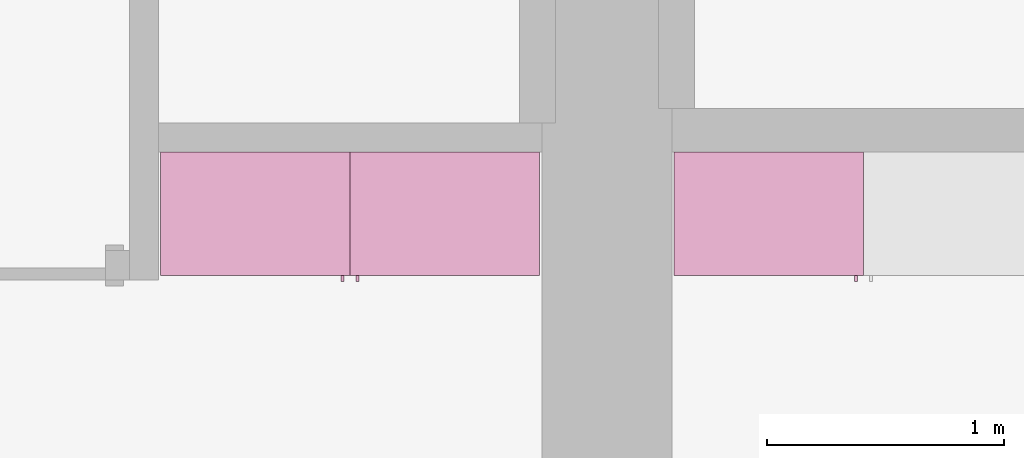
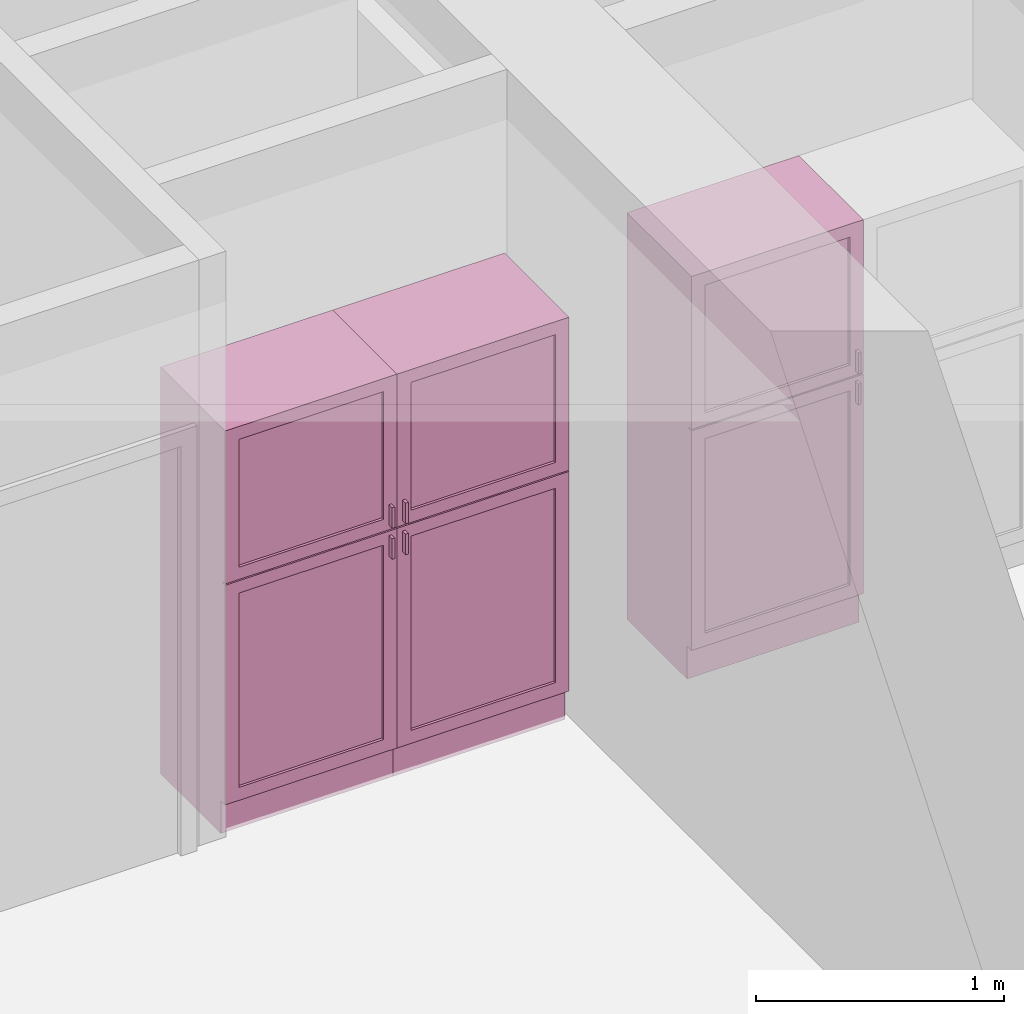
# One storey, part 14 of 16: 3 furnishings, 3 openings.
"""IFC2X3 building model written with IfcOpenShell, lengths in metres."""

from ifc_helpers import new_model, entity, si_unit, converted_unit, frame, frame_2d, origin, origin_2d_with_axis, place, context, project, spatial, rectangle, extrude, face_set, surface_model, source, transform, mapped, type_object, type_shapes, element, save


model = new_model("IFC2X3")

# Units and contexts
model_context = context("Model", 3, precision=1e-09, world=origin())
plan_context = context("Plan", 3, precision=1e-09, world=origin())
ifc_project = project(units=[si_unit("LENGTHUNIT", "METRE"), si_unit("AREAUNIT", "SQUARE_METRE"), si_unit("VOLUMEUNIT", "CUBIC_METRE"), converted_unit("PLANEANGLEUNIT", "DEGREE", entity("IfcRatioMeasure", 0.01745329251994328), si_unit("PLANEANGLEUNIT", "RADIAN"), dimensions=[0, 0, 0, 0, 0, 0, 0]), si_unit("TIMEUNIT", "SECOND")], contexts=[model_context, plan_context])

# Site, building, storey, space
site_placement = place(None, origin())
site = spatial("IfcSite", under=ifc_project, at=site_placement, CompositionType="ELEMENT")
building_placement = place(site_placement, origin())
building = spatial("IfcBuilding", under=site, at=building_placement, CompositionType="ELEMENT")
storey_placement = place(building_placement, frame((0.0, 0.0, 3.100000000000196)))
storey = spatial("IfcBuildingStorey", under=building, at=storey_placement, Name="Level 2", CompositionType="ELEMENT", Elevation=3.100000000000196)
space_1_placement = place(storey_placement, origin())
space_1 = spatial("IfcSpace", under=storey, at=space_1_placement, CompositionType="ELEMENT", InteriorOrExteriorSpace="INTERNAL")

# Furnishing, opening
furniture_type_1 = type_object("IfcFurnitureType", Name="800 mm", AssemblyPlace="NOTDEFINED")
shared_shape_1 = source(origin(), model_context, "Body", "SurfaceModel", [
    surface_model("IfcFaceBasedSurfaceModel", [(0.7999999999999998, 0.04444999999999991, 0.1615874999998423), (0.0, 0.04445000000000255, 0.1615874999998423), (0.0, 0.04445000000000255, 2.0), (0.7999999999999998, 0.04444999999999991, 2.0), (0.7809499999999974, 0.04444999999999998, 1.980949999999954), (0.01904999999999817, 0.04445000000000248, 1.980949999999954), (0.01904999999999817, 0.04445000000000248, 0.1806374999998427), (0.7809499999999974, 0.04444999999999998, 0.1806374999998428), (0.0, 0.5454000000000022, 2.0), (0.8000000000000014, 0.5453999999999996, 2.0), (0.8000000000000026, 0.5453999999999996, 0.0), (0.0, 0.5454000000000009, 0.0), (0.780949999999999, 0.5453999999999996, 1.980949999999954), (0.0190499999999998, 0.5454000000000021, 1.980949999999954), (0.0190499999999998, 0.5454000000000021, 0.1806374999998428), (0.780949999999999, 0.5453999999999996, 0.1806374999998428), (0.7999999999999999, 0.06040000000000177, 0.1615874999998423), (0.7999999999999999, 0.06040000000000177, 0.0), (0.0, 0.06040000000000177, 0.0), (0.0, 0.06040000000000177, 0.1615874999998318), (0.7745999999999997, 0.0, 1.371548036695815), (0.7745999999999997, 0.0, 1.269948036695815), (0.7620677683693553, 0.0, 1.269948036695815), (0.7620677683693553, 0.0, 1.371548036695815), (0.7745999999999988, 0.0, 1.219148036695816), (0.7745999999999988, 0.0, 1.117548036695818), (0.7620677683693542, 0.0, 1.117548036695818), (0.7620677683693542, 0.0, 1.219148036695816), (0.7745999999999998, 0.02539999999999998, 1.371548036695815), (0.7745999999999998, 0.02539999999999998, 1.269948036695815), (0.7620677683693555, 0.02540000000000005, 1.269948036695815), (0.7620677683693555, 0.02540000000000005, 1.371548036695815), (0.7745999999999988, 0.02539999999999998, 1.219148036695816), (0.7745999999999988, 0.02539999999999998, 1.117548036695818), (0.7620677683693542, 0.02540000000000005, 1.117548036695818), (0.7620677683693542, 0.02540000000000005, 1.219148036695816), (0.7364999999999996, 0.03810000000000007, 1.936499999999956), (0.7364999999999996, 0.03810000000000007, 1.308048036695816), (0.06350000000000126, 0.03810000000000231, 1.308048036695816), (0.06350000000000126, 0.03810000000000231, 1.936499999999956), (0.736499999999999, 0.03810000000000007, 1.181048036695814), (0.736499999999999, 0.03810000000000007, 0.2250874999998395), (0.06350000000000072, 0.03810000000000231, 0.2250874999998395), (0.06350000000000072, 0.03810000000000231, 1.181048036695814), (0.7364999999999996, 0.04445000000000005, 1.936499999999956), (0.7364999999999996, 0.04445000000000005, 1.308048036695816), (0.06350000000000126, 0.04445000000000228, 1.308048036695816), (0.06350000000000126, 0.04445000000000228, 1.936499999999956), (0.736499999999999, 0.04445000000000005, 1.181048036695814), (0.736499999999999, 0.04445000000000005, 0.2250874999998395), (0.06350000000000072, 0.04445000000000228, 0.2250874999998395), (0.06350000000000072, 0.04445000000000228, 1.181048036695814), (0.8, 0.02539999999999984, 2.0), (0.8, 0.02539999999999984, 1.247723036695813), (0.0, 0.02540000000000248, 1.247723036695813), (0.0, 0.02540000000000248, 2.0), (0.7364999999999996, 0.02540000000000005, 1.936499999999956), (0.0635000000000012, 0.02540000000000228, 1.936499999999956), (0.0635000000000012, 0.02540000000000228, 1.308048036695816), (0.7364999999999996, 0.02540000000000005, 1.308048036695816), (0.7999999999999998, 0.02539999999999984, 0.1615874999998214), (0.0, 0.02540000000000248, 0.1615874999998214), (0.0, 0.02540000000000248, 1.241373036695815), (0.7999999999999998, 0.02539999999999984, 1.241373036695815), (0.736499999999999, 0.02540000000000005, 1.181048036695817), (0.06350000000000065, 0.02540000000000228, 1.181048036695817), (0.06350000000000065, 0.02540000000000228, 0.2250874999998395), (0.736499999999999, 0.02540000000000005, 0.2250874999998395), (0.8000000000000002, 0.04444999999999984, 2.0), (0.8000000000000002, 0.04444999999999984, 1.247723036695813), (0.0, 0.04445000000000248, 1.247723036695813), (0.0, 0.04445000000000248, 2.0), (0.7364999999999996, 0.04445000000000005, 1.936499999999956), (0.06350000000000126, 0.04445000000000228, 1.936499999999956), (0.06350000000000126, 0.04445000000000228, 1.308048036695816), (0.7364999999999996, 0.04445000000000005, 1.308048036695816), (0.7999999999999999, 0.04444999999999984, 0.1615874999998214), (0.0, 0.04445000000000248, 0.1615874999998214), (0.0, 0.04445000000000248, 1.241373036695815), (0.7999999999999999, 0.04444999999999984, 1.241373036695815), (0.736499999999999, 0.04445000000000005, 1.181048036695817), (0.06350000000000072, 0.04445000000000228, 1.181048036695817), (0.06350000000000072, 0.04445000000000228, 0.2250874999998395), (0.736499999999999, 0.04445000000000005, 0.2250874999998395), (0.7809499999999987, 0.5263500000000009, 1.980949999999952), (0.7809499999999988, 0.5263500000000009, 0.1806374999998463), (0.01904999999999987, 0.5263500000000009, 0.1806374999998463), (0.0190499999999998, 0.5263500000000009, 1.980949999999952), (0.7809499999999987, 0.5454000000000009, 1.980949999999952), (0.7809499999999987, 0.5454000000000009, 0.1806374999998463), (0.0190499999999998, 0.5454000000000009, 0.1806374999998463), (0.0190499999999998, 0.5454000000000009, 1.980949999999952)], [face_set([[[0, 1, 2, 3], [4, 5, 6, 7]], [[8, 9, 10, 11], [12, 13, 14, 15]], [[3, 0, 16, 17, 10, 9]], [[2, 8, 9, 3]], [[1, 2, 8, 11, 18, 19]], [[0, 1, 19, 16]], [[7, 15, 12, 4]], [[6, 14, 15, 7]], [[5, 13, 14, 6]], [[4, 5, 13, 12]], [[10, 17, 18, 11]], [[18, 19, 16, 17]]]), face_set([[[20, 21, 22, 23]], [[24, 25, 26, 27]], [[28, 29, 30, 31]], [[32, 33, 34, 35]], [[23, 31, 28, 20]], [[22, 23, 31, 30]], [[21, 22, 30, 29]], [[20, 28, 29, 21]], [[27, 35, 32, 24]], [[26, 27, 35, 34]], [[25, 26, 34, 33]], [[24, 32, 33, 25]]]), face_set([[[36, 37, 38, 39]], [[40, 41, 42, 43]], [[44, 45, 46, 47]], [[48, 49, 50, 51]], [[39, 47, 44, 36]], [[38, 46, 47, 39]], [[37, 38, 46, 45]], [[36, 37, 45, 44]], [[43, 51, 48, 40]], [[42, 50, 51, 43]], [[41, 42, 50, 49]], [[40, 41, 49, 48]]]), face_set([[[52, 53, 54, 55], [56, 57, 58, 59]], [[60, 61, 62, 63], [64, 65, 66, 67]], [[68, 69, 70, 71], [72, 73, 74, 75]], [[76, 77, 78, 79], [80, 81, 82, 83]], [[55, 71, 68, 52]], [[54, 55, 71, 70]], [[53, 54, 70, 69]], [[52, 53, 69, 68]], [[63, 60, 76, 79]], [[62, 78, 79, 63]], [[61, 62, 78, 77]], [[60, 61, 77, 76]], [[59, 75, 72, 56]], [[58, 74, 75, 59]], [[57, 58, 74, 73]], [[56, 57, 73, 72]], [[67, 83, 80, 64]], [[66, 82, 83, 67]], [[65, 66, 82, 81]], [[64, 65, 81, 80]]]), face_set([[[84, 85, 86, 87]], [[88, 89, 90, 91]], [[87, 91, 88, 84]], [[86, 87, 91, 90]], [[85, 86, 90, 89]], [[84, 85, 89, 88]]])]),
])
type_shapes(furniture_type_1, [shared_shape_1])
furnishing_1_placement = place(space_1_placement, frame((2.513999999999991, -11.6794, 0.0)))
furnishing_1 = element("IfcFurnishingElement", 1, at=furnishing_1_placement, inside=space_1, type_object=furniture_type_1, ObjectType="800 mm", context=model_context, shape_type="MappedRepresentation", body=[
    mapped(shared_shape_1, transform((0.0, 0.0, 0.0), scale=1.0)),
])
opening_1_placement = place(space_1_placement, frame((2.513999999999991, -11.6794, 0.0)))
element("IfcOpeningElement", 2, at=opening_1_placement, cuts=furnishing_1, ObjectType="Opening", context=model_context, shape_type="SweptSolid", body=[
    extrude(rectangle(XDim=1.800312500000111, YDim=0.7618999999999992, at=frame_2d((0.0, 0.0), x_axis=(0.0, 1.0))), frame((0.01873770491802511, 0.0, -2.019206250000297), z_axis=(0.0, -1.0, 0.0), x_axis=(-1.0, 0.0, 0.0)), (0.0, 0.0, 1.0), 0.5009499999999997),
])

furniture_type_2 = type_object("IfcFurnitureType", Name="800 mm", AssemblyPlace="NOTDEFINED")
shared_shape_2 = source(origin(), model_context, "Body", "SurfaceModel", [
    surface_model("IfcFaceBasedSurfaceModel", [(0.7999999999999998, 0.5009500000000022, 0.1615874999998423), (0.7999999999999998, 0.5009500000000022, 2.0), (0.0, 0.5009499999999997, 2.0), (0.0, 0.5009499999999997, 0.1615874999998423), (0.7809499999999974, 0.5009500000000022, 1.980949999999954), (0.7809499999999974, 0.5009500000000022, 0.1806374999998428), (0.01904999999999817, 0.5009499999999997, 0.1806374999998428), (0.01904999999999817, 0.5009499999999997, 1.980949999999954), (0.0, 0.0, 2.0), (0.0, 0.0, 0.0), (0.8000000000000026, 0.0, 0.0), (0.8000000000000014, 0.0, 2.0), (0.780949999999999, 0.0, 1.980949999999954), (0.780949999999999, 0.0, 0.1806374999998428), (0.0190499999999998, 0.0, 0.1806374999998427), (0.0190499999999998, 0.0, 1.980949999999954), (0.8000000000000026, 0.4850000000000004, 0.0), (0.7999999999999999, 0.4850000000000004, 0.1615874999998318), (0.0, 0.4850000000000004, 0.0), (0.0, 0.4850000000000004, 0.1615874999998423), (0.7745999999999997, 0.5454000000000022, 1.371548036695815), (0.7620677683693553, 0.5454000000000021, 1.371548036695815), (0.7620677683693553, 0.5454000000000021, 1.269948036695815), (0.7745999999999997, 0.5454000000000022, 1.269948036695815), (0.7745999999999988, 0.5454000000000022, 1.219148036695816), (0.7620677683693542, 0.5454000000000021, 1.219148036695816), (0.7620677683693542, 0.5454000000000021, 1.117548036695818), (0.7745999999999988, 0.5454000000000022, 1.117548036695818), (0.7745999999999998, 0.5200000000000022, 1.371548036695815), (0.7620677683693555, 0.5200000000000021, 1.371548036695815), (0.7620677683693555, 0.5200000000000021, 1.269948036695815), (0.7745999999999998, 0.5200000000000022, 1.269948036695815), (0.7745999999999988, 0.5200000000000022, 1.219148036695816), (0.7620677683693542, 0.5200000000000021, 1.219148036695816), (0.7620677683693542, 0.5200000000000021, 1.117548036695818), (0.7745999999999988, 0.5200000000000022, 1.117548036695818), (0.7364999999999996, 0.5073000000000021, 1.936499999999956), (0.06350000000000126, 0.5072999999999999, 1.936499999999956), (0.06350000000000126, 0.5072999999999999, 1.308048036695816), (0.7364999999999996, 0.5073000000000021, 1.308048036695816), (0.736499999999999, 0.5073000000000021, 1.181048036695814), (0.06350000000000072, 0.5072999999999999, 1.181048036695814), (0.06350000000000072, 0.5072999999999999, 0.2250874999998395), (0.736499999999999, 0.5073000000000021, 0.2250874999998395), (0.7364999999999996, 0.5009500000000021, 1.936499999999956), (0.06350000000000126, 0.5009499999999999, 1.936499999999956), (0.06350000000000126, 0.5009499999999999, 1.308048036695816), (0.7364999999999996, 0.5009500000000021, 1.308048036695816), (0.736499999999999, 0.5009500000000021, 1.181048036695814), (0.06350000000000072, 0.5009499999999999, 1.181048036695814), (0.06350000000000072, 0.5009499999999999, 0.2250874999998395), (0.736499999999999, 0.5009500000000021, 0.2250874999998395), (0.8, 0.5200000000000023, 2.0), (0.0, 0.5199999999999997, 2.0), (0.0, 0.5199999999999997, 1.247723036695813), (0.8, 0.5200000000000023, 1.247723036695813), (0.7364999999999996, 0.5200000000000021, 1.936499999999956), (0.7364999999999996, 0.5200000000000021, 1.308048036695816), (0.0635000000000012, 0.5199999999999999, 1.308048036695816), (0.0635000000000012, 0.5199999999999999, 1.936499999999956), (0.7999999999999998, 0.5200000000000023, 0.1615874999998214), (0.7999999999999998, 0.5200000000000023, 1.241373036695815), (0.0, 0.5199999999999997, 1.241373036695815), (0.0, 0.5199999999999997, 0.1615874999998214), (0.736499999999999, 0.5200000000000021, 1.181048036695817), (0.736499999999999, 0.5200000000000021, 0.2250874999998395), (0.06350000000000065, 0.5199999999999999, 0.2250874999998395), (0.06350000000000065, 0.5199999999999999, 1.181048036695817), (0.8000000000000002, 0.5009500000000023, 2.0), (0.0, 0.5009499999999997, 2.0), (0.0, 0.5009499999999997, 1.247723036695813), (0.8, 0.5009500000000023, 1.247723036695813), (0.7364999999999996, 0.5009500000000021, 1.936499999999956), (0.7364999999999996, 0.5009500000000021, 1.308048036695816), (0.06350000000000126, 0.5009499999999999, 1.308048036695816), (0.06350000000000126, 0.5009499999999999, 1.936499999999956), (0.7999999999999999, 0.5009500000000023, 0.1615874999998214), (0.7999999999999999, 0.5009500000000023, 1.241373036695815), (0.0, 0.5009499999999997, 1.241373036695815), (0.0, 0.5009499999999997, 0.1615874999998214), (0.736499999999999, 0.5009500000000021, 1.181048036695817), (0.736499999999999, 0.5009500000000021, 0.2250874999998395), (0.06350000000000072, 0.5009499999999999, 0.2250874999998395), (0.06350000000000072, 0.5009499999999999, 1.181048036695817), (0.7809499999999987, 0.01905000000000129, 1.980949999999952), (0.0190499999999998, 0.01905000000000129, 1.980949999999952), (0.0190499999999998, 0.01905000000000129, 0.1806374999998463), (0.7809499999999987, 0.01905000000000129, 0.1806374999998463), (0.7809499999999987, 0.0, 1.980949999999952), (0.0190499999999998, 0.0, 1.980949999999952), (0.01904999999999987, 0.0, 0.1806374999998463), (0.7809499999999988, 0.0, 0.1806374999998463)], [face_set([[[0, 1, 2, 3], [4, 5, 6, 7]], [[8, 9, 10, 11], [12, 13, 14, 15]], [[1, 11, 10, 16, 17, 0]], [[2, 1, 11, 8]], [[3, 2, 8, 9, 18, 19]], [[0, 17, 19, 3]], [[5, 4, 12, 13]], [[6, 5, 13, 14]], [[7, 6, 14, 15]], [[4, 12, 15, 7]], [[10, 9, 18, 16]], [[18, 16, 17, 19]]]), face_set([[[20, 21, 22, 23]], [[24, 25, 26, 27]], [[28, 29, 30, 31]], [[32, 33, 34, 35]], [[21, 20, 28, 29]], [[22, 30, 29, 21]], [[23, 31, 30, 22]], [[20, 23, 31, 28]], [[25, 24, 32, 33]], [[26, 34, 33, 25]], [[27, 35, 34, 26]], [[24, 27, 35, 32]]]), face_set([[[36, 37, 38, 39]], [[40, 41, 42, 43]], [[44, 45, 46, 47]], [[48, 49, 50, 51]], [[37, 36, 44, 45]], [[38, 37, 45, 46]], [[39, 47, 46, 38]], [[36, 44, 47, 39]], [[41, 40, 48, 49]], [[42, 41, 49, 50]], [[43, 51, 50, 42]], [[40, 48, 51, 43]]]), face_set([[[52, 53, 54, 55], [56, 57, 58, 59]], [[60, 61, 62, 63], [64, 65, 66, 67]], [[68, 69, 70, 71], [72, 73, 74, 75]], [[76, 77, 78, 79], [80, 81, 82, 83]], [[53, 52, 68, 69]], [[54, 70, 69, 53]], [[55, 71, 70, 54]], [[52, 68, 71, 55]], [[61, 77, 76, 60]], [[62, 61, 77, 78]], [[63, 79, 78, 62]], [[60, 76, 79, 63]], [[57, 56, 72, 73]], [[58, 57, 73, 74]], [[59, 75, 74, 58]], [[56, 72, 75, 59]], [[65, 64, 80, 81]], [[66, 65, 81, 82]], [[67, 83, 82, 66]], [[64, 80, 83, 67]]]), face_set([[[84, 85, 86, 87]], [[88, 89, 90, 91]], [[85, 84, 88, 89]], [[86, 90, 89, 85]], [[87, 91, 90, 86]], [[84, 88, 91, 87]]])]),
])
type_shapes(furniture_type_2, [shared_shape_2])
furnishing_2_placement = place(space_1_placement, frame((4.113999999999993, -11.134, 0.0), z_axis=(0.0, 0.0, 1.0), x_axis=(-1.0, 0.0, 0.0)))
furnishing_2 = element("IfcFurnishingElement", 3, at=furnishing_2_placement, inside=space_1, type_object=furniture_type_2, ObjectType="800 mm", context=model_context, shape_type="MappedRepresentation", body=[
    mapped(shared_shape_2, transform((0.0, 0.0, 0.0), scale=1.0)),
])
opening_2_placement = place(space_1_placement, frame((4.113999999999993, -11.134, 0.0), z_axis=(0.0, 0.0, 1.0), x_axis=(-1.0, 0.0, 0.0)))
element("IfcOpeningElement", 4, at=opening_2_placement, cuts=furnishing_2, ObjectType="Opening", context=model_context, shape_type="SweptSolid", body=[
    extrude(rectangle(XDim=1.800312500000111, YDim=0.7618999999999992, at=origin_2d_with_axis()), frame((-0.01873770491802511, 0.0, -2.019206250000297), z_axis=(0.0, -1.0, 0.0), x_axis=(0.0, 0.0, -1.0)), (0.0, 0.0, 1.0), 0.5009499999999997),
])

# Space
space_2_placement = place(storey_placement, origin())
space_2 = spatial("IfcSpace", under=storey, at=space_2_placement, CompositionType="ELEMENT", InteriorOrExteriorSpace="INTERNAL")

# Furnishing, opening
furniture_type_3 = type_object("IfcFurnitureType", Name="800 mm", AssemblyPlace="NOTDEFINED")
shared_shape_3 = source(origin(), model_context, "Body", "SurfaceModel", [
    surface_model("IfcFaceBasedSurfaceModel", [(0.7999999999999998, 0.04444999999999991, 0.1615874999998423), (0.0, 0.04445000000000255, 0.1615874999998423), (0.0, 0.04445000000000255, 2.0), (0.7999999999999998, 0.04444999999999991, 2.0), (0.7809499999999974, 0.04444999999999998, 1.980949999999954), (0.01904999999999817, 0.04445000000000248, 1.980949999999954), (0.01904999999999817, 0.04445000000000248, 0.1806374999998427), (0.7809499999999974, 0.04444999999999998, 0.1806374999998428), (0.0, 0.5454000000000022, 2.0), (0.8000000000000014, 0.5453999999999996, 2.0), (0.8000000000000026, 0.5453999999999996, 0.0), (0.0, 0.5454000000000009, 0.0), (0.780949999999999, 0.5453999999999996, 1.980949999999954), (0.0190499999999998, 0.5454000000000021, 1.980949999999954), (0.0190499999999998, 0.5454000000000021, 0.1806374999998428), (0.780949999999999, 0.5453999999999996, 0.1806374999998428), (0.7999999999999999, 0.06040000000000177, 0.1615874999998423), (0.7999999999999999, 0.06040000000000177, 0.0), (0.0, 0.06040000000000177, 0.0), (0.0, 0.06040000000000177, 0.1615874999998318), (0.7745999999999997, 0.0, 1.371548036695815), (0.7745999999999997, 0.0, 1.269948036695815), (0.7620677683693553, 0.0, 1.269948036695815), (0.7620677683693553, 0.0, 1.371548036695815), (0.7745999999999988, 0.0, 1.219148036695816), (0.7745999999999988, 0.0, 1.117548036695818), (0.7620677683693542, 0.0, 1.117548036695818), (0.7620677683693542, 0.0, 1.219148036695816), (0.7745999999999998, 0.02539999999999998, 1.371548036695815), (0.7745999999999998, 0.02539999999999998, 1.269948036695815), (0.7620677683693555, 0.02540000000000005, 1.269948036695815), (0.7620677683693555, 0.02540000000000005, 1.371548036695815), (0.7745999999999988, 0.02539999999999998, 1.219148036695816), (0.7745999999999988, 0.02539999999999998, 1.117548036695818), (0.7620677683693542, 0.02540000000000005, 1.117548036695818), (0.7620677683693542, 0.02540000000000005, 1.219148036695816), (0.7364999999999996, 0.03810000000000007, 1.936499999999956), (0.7364999999999996, 0.03810000000000007, 1.308048036695816), (0.06350000000000126, 0.03810000000000231, 1.308048036695816), (0.06350000000000126, 0.03810000000000231, 1.936499999999956), (0.736499999999999, 0.03810000000000007, 1.181048036695814), (0.736499999999999, 0.03810000000000007, 0.2250874999998395), (0.06350000000000072, 0.03810000000000231, 0.2250874999998395), (0.06350000000000072, 0.03810000000000231, 1.181048036695814), (0.7364999999999996, 0.04445000000000005, 1.936499999999956), (0.7364999999999996, 0.04445000000000005, 1.308048036695816), (0.06350000000000126, 0.04445000000000228, 1.308048036695816), (0.06350000000000126, 0.04445000000000228, 1.936499999999956), (0.736499999999999, 0.04445000000000005, 1.181048036695814), (0.736499999999999, 0.04445000000000005, 0.2250874999998395), (0.06350000000000072, 0.04445000000000228, 0.2250874999998395), (0.06350000000000072, 0.04445000000000228, 1.181048036695814), (0.8, 0.02539999999999984, 2.0), (0.8, 0.02539999999999984, 1.247723036695813), (0.0, 0.02540000000000248, 1.247723036695813), (0.0, 0.02540000000000248, 2.0), (0.7364999999999996, 0.02540000000000005, 1.936499999999956), (0.0635000000000012, 0.02540000000000228, 1.936499999999956), (0.0635000000000012, 0.02540000000000228, 1.308048036695816), (0.7364999999999996, 0.02540000000000005, 1.308048036695816), (0.7999999999999998, 0.02539999999999984, 0.1615874999998214), (0.0, 0.02540000000000248, 0.1615874999998214), (0.0, 0.02540000000000248, 1.241373036695815), (0.7999999999999998, 0.02539999999999984, 1.241373036695815), (0.736499999999999, 0.02540000000000005, 1.181048036695817), (0.06350000000000065, 0.02540000000000228, 1.181048036695817), (0.06350000000000065, 0.02540000000000228, 0.2250874999998395), (0.736499999999999, 0.02540000000000005, 0.2250874999998395), (0.8000000000000002, 0.04444999999999984, 2.0), (0.8000000000000002, 0.04444999999999984, 1.247723036695813), (0.0, 0.04445000000000248, 1.247723036695813), (0.0, 0.04445000000000248, 2.0), (0.7364999999999996, 0.04445000000000005, 1.936499999999956), (0.06350000000000126, 0.04445000000000228, 1.936499999999956), (0.06350000000000126, 0.04445000000000228, 1.308048036695816), (0.7364999999999996, 0.04445000000000005, 1.308048036695816), (0.7999999999999999, 0.04444999999999984, 0.1615874999998214), (0.0, 0.04445000000000248, 0.1615874999998214), (0.0, 0.04445000000000248, 1.241373036695815), (0.7999999999999999, 0.04444999999999984, 1.241373036695815), (0.736499999999999, 0.04445000000000005, 1.181048036695817), (0.06350000000000072, 0.04445000000000228, 1.181048036695817), (0.06350000000000072, 0.04445000000000228, 0.2250874999998395), (0.736499999999999, 0.04445000000000005, 0.2250874999998395), (0.7809499999999987, 0.5263500000000009, 1.980949999999952), (0.7809499999999988, 0.5263500000000009, 0.1806374999998463), (0.01904999999999987, 0.5263500000000009, 0.1806374999998463), (0.0190499999999998, 0.5263500000000009, 1.980949999999952), (0.7809499999999987, 0.5454000000000009, 1.980949999999952), (0.7809499999999987, 0.5454000000000009, 0.1806374999998463), (0.0190499999999998, 0.5454000000000009, 0.1806374999998463), (0.0190499999999998, 0.5454000000000009, 1.980949999999952)], [face_set([[[0, 1, 2, 3], [4, 5, 6, 7]], [[8, 9, 10, 11], [12, 13, 14, 15]], [[3, 0, 16, 17, 10, 9]], [[2, 8, 9, 3]], [[1, 2, 8, 11, 18, 19]], [[0, 1, 19, 16]], [[7, 15, 12, 4]], [[6, 14, 15, 7]], [[5, 13, 14, 6]], [[4, 5, 13, 12]], [[10, 17, 18, 11]], [[18, 19, 16, 17]]]), face_set([[[20, 21, 22, 23]], [[24, 25, 26, 27]], [[28, 29, 30, 31]], [[32, 33, 34, 35]], [[23, 31, 28, 20]], [[22, 23, 31, 30]], [[21, 22, 30, 29]], [[20, 28, 29, 21]], [[27, 35, 32, 24]], [[26, 27, 35, 34]], [[25, 26, 34, 33]], [[24, 32, 33, 25]]]), face_set([[[36, 37, 38, 39]], [[40, 41, 42, 43]], [[44, 45, 46, 47]], [[48, 49, 50, 51]], [[39, 47, 44, 36]], [[38, 46, 47, 39]], [[37, 38, 46, 45]], [[36, 37, 45, 44]], [[43, 51, 48, 40]], [[42, 50, 51, 43]], [[41, 42, 50, 49]], [[40, 41, 49, 48]]]), face_set([[[52, 53, 54, 55], [56, 57, 58, 59]], [[60, 61, 62, 63], [64, 65, 66, 67]], [[68, 69, 70, 71], [72, 73, 74, 75]], [[76, 77, 78, 79], [80, 81, 82, 83]], [[55, 71, 68, 52]], [[54, 55, 71, 70]], [[53, 54, 70, 69]], [[52, 53, 69, 68]], [[63, 60, 76, 79]], [[62, 78, 79, 63]], [[61, 62, 78, 77]], [[60, 61, 77, 76]], [[59, 75, 72, 56]], [[58, 74, 75, 59]], [[57, 58, 74, 73]], [[56, 57, 73, 72]], [[67, 83, 80, 64]], [[66, 82, 83, 67]], [[65, 66, 82, 81]], [[64, 65, 81, 80]]]), face_set([[[84, 85, 86, 87]], [[88, 89, 90, 91]], [[87, 91, 88, 84]], [[86, 87, 91, 90]], [[85, 86, 90, 89]], [[84, 85, 89, 88]]])]),
])
type_shapes(furniture_type_3, [shared_shape_3])
furnishing_3_placement = place(space_2_placement, frame((4.682999999999983, -11.67940000000001, 0.0)))
furnishing_3 = element("IfcFurnishingElement", 5, at=furnishing_3_placement, inside=space_2, type_object=furniture_type_3, ObjectType="800 mm", context=model_context, shape_type="MappedRepresentation", body=[
    mapped(shared_shape_3, transform((0.0, 0.0, 0.0), scale=1.0)),
])
opening_3_placement = place(space_2_placement, frame((4.682999999999983, -11.67940000000001, 0.0)))
element("IfcOpeningElement", 6, at=opening_3_placement, cuts=furnishing_3, ObjectType="Opening", context=model_context, shape_type="SweptSolid", body=[
    extrude(rectangle(XDim=1.800312500000111, YDim=0.7618999999999992, at=frame_2d((0.0, 0.0), x_axis=(0.0, 1.0))), frame((0.01873770491802511, 0.0, -2.019206250000297), z_axis=(0.0, -1.0, 0.0), x_axis=(-1.0, 0.0, 0.0)), (0.0, 0.0, 1.0), 0.5009499999999997),
])

save(model, "model.ifc")
